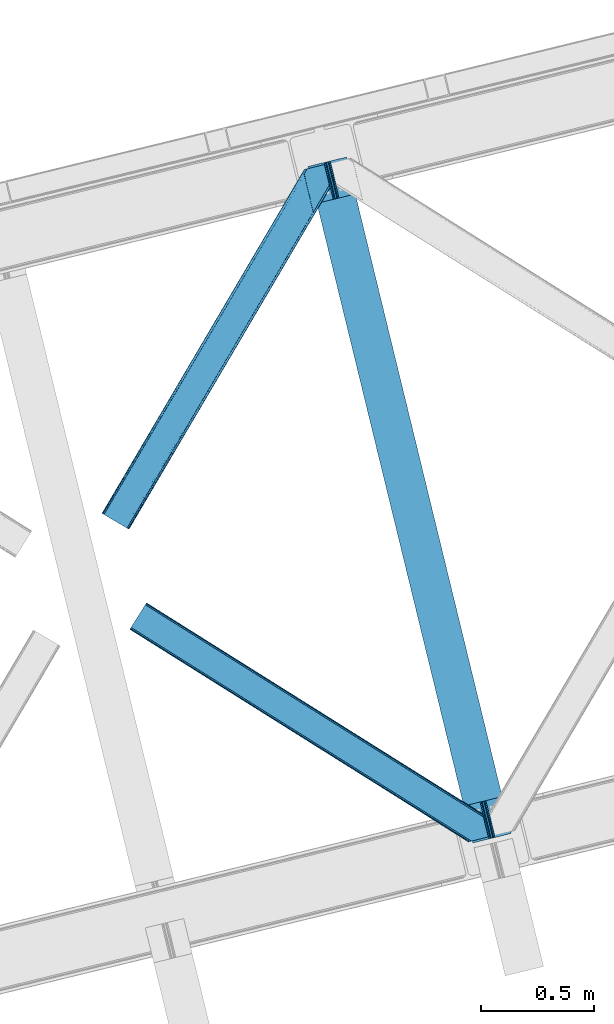
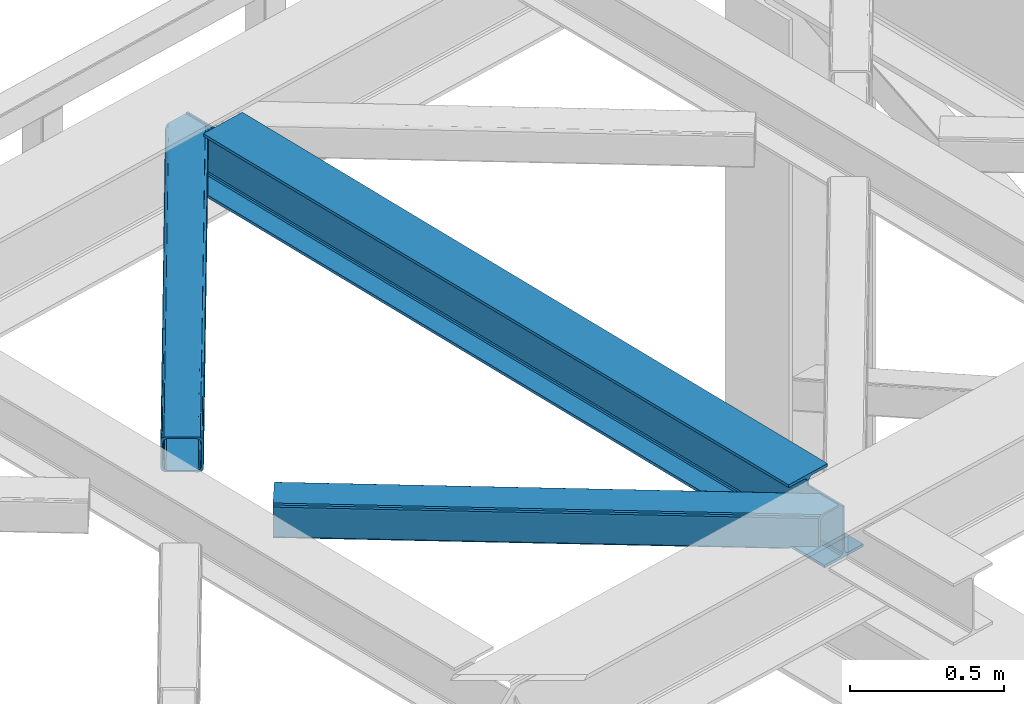
# One storey, part 25 of 93: 2 members, 1 beam.
"""IFC4 building model written with IfcOpenShell, lengths in millimetres."""

from ifc_helpers import new_model, entity, si_unit, converted_unit, derived_unit, direction, frame, origin, place, context, subcontext, project, spatial, triangles, polygons, material, type_object, element, save


model = new_model("IFC4")

# Units and contexts
model_context = context("Model", 3, precision=0.01, world=origin(), true_north=direction((6.12303176911189e-17, 1.0)))
plan_context = context("Plan", 3, precision=0.01, world=origin(), true_north=direction((6.12303176911189e-17, 1.0)))
body_context = subcontext(model_context, "Body", "Model", "MODEL_VIEW")
ifc_project = project(units=[si_unit("LENGTHUNIT", "METRE", prefix="MILLI"), si_unit("AREAUNIT", "SQUARE_METRE"), si_unit("VOLUMEUNIT", "CUBIC_METRE"), converted_unit("PLANEANGLEUNIT", "DEGREE", entity("IfcRatioMeasure", 0.0174532925199433), si_unit("PLANEANGLEUNIT", "RADIAN"), dimensions=[0, 0, 0, 0, 0, 0, 0]), si_unit("MASSUNIT", "GRAM", prefix="KILO"), derived_unit("MASSDENSITYUNIT", [(si_unit("MASSUNIT", "GRAM", prefix="KILO"), 1), (si_unit("LENGTHUNIT", "METRE"), -3)]), derived_unit("MOMENTOFINERTIAUNIT", [(si_unit("LENGTHUNIT", "METRE"), 4)]), si_unit("TIMEUNIT", "SECOND"), si_unit("FREQUENCYUNIT", "HERTZ"), si_unit("THERMODYNAMICTEMPERATUREUNIT", "DEGREE_CELSIUS"), derived_unit("THERMALTRANSMITTANCEUNIT", [(si_unit("MASSUNIT", "GRAM", prefix="KILO"), 1), (si_unit("THERMODYNAMICTEMPERATUREUNIT", "KELVIN"), -1), (si_unit("TIMEUNIT", "SECOND"), -3)]), derived_unit("VOLUMETRICFLOWRATEUNIT", [(si_unit("LENGTHUNIT", "METRE"), 3), (si_unit("TIMEUNIT", "SECOND"), -1)]), derived_unit("MASSFLOWRATEUNIT", [(si_unit("MASSUNIT", "GRAM", prefix="KILO"), 1), (si_unit("TIMEUNIT", "SECOND"), -1)]), derived_unit("ROTATIONALFREQUENCYUNIT", [(si_unit("TIMEUNIT", "SECOND"), -1)]), si_unit("ELECTRICCURRENTUNIT", "AMPERE"), si_unit("ELECTRICVOLTAGEUNIT", "VOLT"), si_unit("POWERUNIT", "WATT"), si_unit("FORCEUNIT", "NEWTON", prefix="KILO"), si_unit("ILLUMINANCEUNIT", "LUX"), si_unit("LUMINOUSFLUXUNIT", "LUMEN"), si_unit("LUMINOUSINTENSITYUNIT", "CANDELA"), derived_unit("USERDEFINED", [(si_unit("MASSUNIT", "GRAM", prefix="KILO"), -1), (si_unit("LENGTHUNIT", "METRE"), -2), (si_unit("TIMEUNIT", "SECOND"), 3), (si_unit("LUMINOUSFLUXUNIT", "LUMEN"), 1)]), derived_unit("LINEARVELOCITYUNIT", [(si_unit("LENGTHUNIT", "METRE"), 1), (si_unit("TIMEUNIT", "SECOND"), -1)]), si_unit("PRESSUREUNIT", "PASCAL"), derived_unit("USERDEFINED", [(si_unit("LENGTHUNIT", "METRE"), -2), (si_unit("MASSUNIT", "GRAM", prefix="KILO"), 1), (si_unit("TIMEUNIT", "SECOND"), -2)]), derived_unit("LINEARFORCEUNIT", [(si_unit("MASSUNIT", "GRAM", prefix="KILO"), 1), (si_unit("LENGTHUNIT", "METRE"), 1), (si_unit("TIMEUNIT", "SECOND"), -2), (si_unit("LENGTHUNIT", "METRE"), -1)]), derived_unit("PLANARFORCEUNIT", [(si_unit("MASSUNIT", "GRAM", prefix="KILO"), 1), (si_unit("LENGTHUNIT", "METRE"), 1), (si_unit("TIMEUNIT", "SECOND"), -2), (si_unit("LENGTHUNIT", "METRE"), -2)])], contexts=[model_context, plan_context])

# Site, building, storey
site_placement = place(None, origin())
site = spatial("IfcSite", under=ifc_project, at=site_placement, CompositionType="ELEMENT")
building_placement = place(site_placement, origin())
building = spatial("IfcBuilding", under=site, at=building_placement, CompositionType="ELEMENT")
storey_placement = place(building_placement, frame((0.0, 0.0, 15900.0)))
storey = spatial("IfcBuildingStorey", under=building, at=storey_placement, CompositionType="ELEMENT", Elevation=15900.0)

# Beam
ifc_material = material(Name="Metal painted (White)")
beam_type = type_object("IfcBeamType", PredefinedType="BEAM")
beam_placement = place(storey_placement, frame((-58178.5607525834, 3605.06510342686, 3441.0)))
element("IfcBeam", 1, at=beam_placement, inside=storey, type_object=beam_type, material=ifc_material, ObjectType="Steel Beam", PredefinedType="BEAM", context=body_context, shape_type="Tessellation", body=[
    polygons([(900.98534618944, 41.4445662733081, 11.000000000004), (900.98534618944, 41.4445662733081, 2.16573425859679e-12), (170.021610174761, 3040.13999372697, 2.16573425859679e-12), (170.021610174761, 3040.13999372697, 11.000000000004), (834.919806235814, 25.3403919499656, 11.000000000004), (103.956070221135, 3024.03581940362, 11.000000000004), (828.971056214522, 23.8903211957396, 12.2179274798217), (98.0073201998427, 3022.5857486494, 12.2179274798217), (823.927949458413, 22.6610105689194, 15.6862915010192), (92.964213443734, 3021.35643802258, 15.6862915010192), (820.558253255237, 21.8396114687113, 20.8770650821657), (89.5945172405581, 3020.53503892237, 20.8770650821657), (819.374973305543, 21.55117446212, 27.0000000000047), (88.4112372908723, 3020.24660191578, 27.0000000000047), (81.6103728838888, 3018.58881926485, 27.0000000000047), (81.6103728838801, 3018.58881926485, 203.000000000006), (88.4112372908723, 3020.24660191578, 203.000000000006), (0.0, 2998.69542745366, 2.16573425859679e-12), (0.0, 2998.69542745366, 10.9999999999997), (66.0655399536172, 3014.799601777, 11.000000000004), (72.0142899749184, 3016.24967253123, 12.2179274798217), (77.057396731027, 3017.47898315805, 15.6862915010192), (80.4270929342029, 3018.30038225826, 20.8770650821657), (819.374973305543, 21.5511744621206, 203.000000000006), (812.574108898559, 19.8933918111876, 203.000000000006), (812.574108898559, 19.8933918111881, 27.0000000000047), (811.390828948873, 19.6049548045968, 20.8770650821657), (808.021132745689, 18.7835557043887, 15.6862915010192), (802.978025989589, 17.5542450775691, 12.2179274798217), (797.029275968296, 16.1041743233425, 11.000000000004), (730.963736014679, 0.0, 10.9999999999997), (730.963736014679, -5.41433564649196e-13, 2.16573425859679e-12), (779.675212882749, 184.415062601691, 203.069791966819), (128.020401343495, 2857.75452019162, 203.000000000006), (128.24328213265, 2856.8401777572, 203.617301946336), (128.256196377177, 2856.7871977843, 217.000003693143), (779.530009633824, 185.010597404071, 217.000003676718), (779.530880241713, 185.007025963192, 204.00000679514), (772.96491171832, 182.385463974441, 203.006342981529), (772.742064056773, 183.299815969774, 203.617301946336), (772.729149812254, 183.352795942667, 217.000003693143), (121.455336555599, 2855.1293963229, 217.000003676718), (121.45446594771, 2855.13296776378, 204.00000679514), (121.310166358664, 2855.72494066435, 203.076120467494), (121.219536936511, 2856.09673754069, 203.000000000006), (780.71349435786, 185.298194377514, 223.122939328039), (784.082490766539, 186.122464201394, 228.313710402595), (789.125126170554, 187.353708426698, 231.782072735464), (795.073705041275, 188.80448128138, 232.999999602236), (861.139155906781, 204.909021065314, 232.999999283132), (861.137682570343, 204.915065042188, 243.999994005812), (691.116301666431, 163.469558245297, 243.999994827032), (691.117775002877, 163.463514268424, 233.000000104353), (757.183225868401, 179.568054052359, 232.999999785253), (763.132130996731, 181.017488520582, 231.782072861016), (768.17569550387, 182.244921343718, 228.313710479427), (771.546082413602, 183.063487001147, 223.12293937232), (120.271851831572, 2854.84179934945, 223.122939328039), (116.902855422893, 2854.01752952557, 228.313710402595), (111.860220018869, 2852.78628530027, 231.782072735464), (105.911641148174, 2851.33551244559, 232.999999602236), (39.8461902826505, 2835.23097266165, 232.999999283128), (39.8476636190881, 2835.22492868478, 243.999994005812), (209.869044522992, 2876.67043548167, 243.999994827032), (209.867571186554, 2876.67647945854, 233.000000104357), (143.802120321031, 2860.57193967461, 232.999999785253), (137.85321519271, 2859.12250520639, 231.782072861012), (132.809650685579, 2857.89507238325, 228.313710479427), (129.439263775838, 2857.07650672582, 223.12293937232)], [[[1, 2, 3, 4]], [[5, 1, 4, 6]], [[7, 5, 6, 8]], [[9, 7, 8, 10]], [[11, 9, 10, 12]], [[13, 11, 12, 14]], [[15, 16, 17, 14, 12, 10, 8, 6, 4, 3, 18, 19, 20, 21, 22, 23]], [[13, 24, 25, 26, 27, 28, 29, 30, 31, 32, 2, 1, 5, 7, 9, 11]], [[2, 32, 18, 3]], [[32, 31, 19, 18]], [[31, 30, 20, 19]], [[27, 26, 15, 23]], [[28, 27, 23, 22]], [[29, 28, 22, 21]], [[30, 29, 21, 20]], [[33, 24, 13, 14, 17, 34, 35, 36, 37, 38]], [[25, 39, 40, 41, 42, 43, 44, 16, 15, 26]], [[39, 25, 24, 33]], [[45, 34, 17, 16]], [[41, 40, 38, 37, 46, 47, 48, 49, 50, 51, 52, 53, 54, 55, 56, 57]], [[42, 58, 59, 60, 61, 62, 63, 64, 65, 66, 67, 68, 69, 36, 35, 43]], [[46, 37, 36, 69]], [[47, 46, 69, 68]], [[48, 47, 68, 67]], [[49, 48, 67, 66]], [[50, 49, 66, 65]], [[51, 50, 65, 64]], [[52, 51, 64, 63]], [[53, 52, 63, 62]], [[54, 53, 62, 61]], [[55, 54, 61, 60]], [[56, 55, 60, 59]], [[57, 56, 59, 58]], [[41, 57, 58, 42]]], closed=False),
])

# Members
member_type_1 = type_object("IfcMemberType", PredefinedType="BRACE")
member_1_placement = place(storey_placement, frame((-59092.2442382813, 4994.98929748535, 3511.0000579834)))
element("IfcMember", 2, at=member_1_placement, inside=storey, type_object=member_type_1, ObjectType="Steel Horizontal Brace", PredefinedType="BRACE", context=body_context, shape_type="Tessellation", body=[
    triangles([(105.565649414064, 8.87794647216742, 0.0), (15.0828002929702, 62.1479507446284, 0.0), (892.847827148435, 1346.1393447876, 0.0), (857.170935058595, 1492.50250396728, 0.0), (854.896655273435, 1501.83739929199, 1.33247680664135), (9.31105957031104, 65.5459991455073, 1.33247680664135), (852.966540527341, 1509.75145111084, 5.12526855468968), (4.4183349609375, 68.4260559082031, 5.12526855468968), (851.678247070311, 1515.03950042725, 10.8028289794929), (1.14876708984229, 70.3509384155268, 10.8028289794929), (851.222460937497, 1516.89636383057, 17.5000946044929), (0.0, 71.0264785766603, 17.5000946044929), (893.638476562497, 1342.89768218994, 0.155804443362285), (111.337390136716, 5.48047943115216, 1.33247680664135), (899.559045410155, 1344.34119873047, 1.33247680664135), (912.390820312503, 1347.46949615478, 10.8028289794929), (914.195361328122, 1347.90958557129, 17.5000946044929), (120.643798828125, 0.0, 17.5000946044929), (119.499682617185, 0.675540161132631, 10.8028289794929), (907.251599121097, 1346.21666564941, 5.12526855468968), (116.230114746089, 2.59984130859357, 5.12526855468968), (902.498400878903, 1345.05743408203, 17.9802978515654), (893.638476562497, 1342.89768218994, 9.69243164062573), (897.768457031249, 1343.90459747314, 12.1260040283232), (903.726232910158, 1345.35625305176, 19.4999725341804), (914.195361328122, 1347.90958557129, 19.4999725341804), (1011.61732177735, 1513.38611297607, 19.4999725341804), (1008.98957519532, 1524.16103668213, 19.4999725341804), (1011.61732177735, 1513.38611297607, 122.500662231447), (120.643798828125, 0.0, 122.500662231447), (114.61160888672, 3.55094604492206, 24.4996673583992), (1009.24072265625, 1523.14365692139, 24.4996673583992), (113.46749267578, 4.22706756591742, 17.8035644531265), (110.197924804685, 6.15136871337836, 12.1260040283232), (105.305200195311, 9.03200683593695, 8.3320495605476), (99.5334594726519, 12.4294738769531, 6.99957275390625), (892.685046386716, 1346.79976959229, 8.88434143066479), (890.471228027345, 1355.89688873291, 6.99957275390625), (21.114990234375, 58.5970046997072, 6.99957275390625), (859.547534179685, 1482.74496002197, 6.99957275390625), (853.961828613283, 1505.65984039307, 18.5000335693367), (851.222460937497, 1516.89636383057, 18.5000335693367), (854.096704101561, 1505.10871124268, 17.8803039550803), (855.343139648438, 1499.99390716553, 12.1260040283232), (857.273254394531, 1492.07985534668, 8.3320495605476), (1009.24072265625, 1523.14365692139, 115.501089477541), (114.61160888672, 3.55094604492206, 115.501089477541), (1008.78493652344, 1525.00052032471, 122.196029663086), (113.46749267578, 4.22706756591742, 122.196029663086), (1007.49664306641, 1530.28856964111, 127.87475280762), (110.197924804685, 6.15136871337836, 127.87475280762), (1005.57117919922, 1538.20262145996, 131.667544555665), (105.305200195311, 9.03200683593695, 131.667544555665), (1003.29224853516, 1547.53751678467, 133.000021362306), (99.5334594726519, 12.4294738769531, 133.000021362306), (851.952648925784, 1518.13291625977, 19.4999725341804), (854.580395507815, 1507.35799255371, 19.4999725341804), (851.780566406247, 1517.83991088867, 19.2639404296897), (854.43156738281, 1506.94987792969, 19.2592895507842), (851.589880371095, 1517.51434936523, 19.0000030517585), (854.268786621091, 1506.50920715332, 19.0000030517585), (851.394543457034, 1517.1887878418, 18.736065673831), (854.110656738281, 1506.06795501709, 18.7407165527366), (908.014343261719, 1598.12628936768, 19.4999725341804), (897.545214843747, 1595.57353820801, 19.4999725341804), (1011.16618652343, 1515.24297637939, 129.197927856447), (1009.8778930664, 1520.53160705566, 134.874325561526), (1008.43146972657, 1526.45624542236, 137.999716186525), (986.311889648438, 1617.21117095947, 137.999716186525), (986.311889648438, 1617.21117095947, 133.000021362306), (897.545214843747, 1595.57353820801, 122.500662231447), (0.0, 71.0264785766603, 122.500662231447), (7.18095703124709, 66.799411010742, 17.8035644531265), (10.4505249023423, 64.8751098632811, 12.1260040283232), (6.03218994140479, 67.4755325317383, 24.4996673583992), (907.028356933595, 1597.88560638428, 24.4996673583992), (15.3432495117158, 61.9944717407225, 8.3320495605476), (908.832897949222, 1598.32511444092, 122.196029663086), (899.349755859374, 1596.01362762451, 129.197927856447), (904.48897705078, 1597.26645812988, 134.874325561526), (930.738537597659, 1603.66490478516, 133.000021362306), (910.246765136719, 1598.66986083984, 137.999716186525), (921.664672851563, 1601.45341186523, 131.667544555665), (913.972119140628, 1599.57794494629, 127.87475280762), (907.028356933595, 1597.88560638428, 115.501089477541), (21.114990234375, 58.5970046997072, 133.000021362306), (6.03218994140479, 67.4755325317383, 115.501089477541), (15.3432495117158, 61.9944717407225, 131.667544555665), (10.4505249023423, 64.8751098632811, 127.87475280762), (7.18095703124709, 66.799411010742, 122.196029663086), (119.499682617185, 0.675540161132631, 129.197927856447), (116.230114746089, 2.59984130859357, 134.874325561526), (111.337390136716, 5.48047943115216, 138.667117309571), (105.565649414064, 8.87794647216742, 139.999594116212), (15.0828002929702, 62.1479507446284, 139.999594116212), (9.31105957031104, 65.5459991455073, 138.667117309571), (4.4183349609375, 68.4260559082031, 134.874325561526), (1.14876708984229, 70.3509384155268, 129.197927856447), (896.991760253906, 1576.15553741455, 137.999716186525), (938.18924560547, 1407.14434204102, 137.999716186525), (899.024194335936, 1563.5946762085, 139.999594116212), (897.042919921878, 1571.72266845703, 138.999655151369), (896.801074218747, 1573.13653564453, 138.639212036134), (896.926647949222, 1575.15443572998, 138.211331176761), (896.86153564453, 1574.14112548828, 138.427597045898), (937.477661132813, 1407.08562469482, 138.29272155762), (937.077685546872, 1408.09486541748, 138.646188354494), (936.682360839841, 1409.10410614014, 138.999655151369), (934.701086425783, 1417.23209838867, 139.999594116212)], [[1, 2, 3], [4, 3, 2], [5, 4, 6], [2, 6, 4], [7, 5, 8], [6, 8, 5], [9, 7, 10], [8, 10, 7], [11, 9, 12], [10, 12, 9], [1, 3, 13], [13, 14, 1], [13, 15, 14], [16, 17, 18], [18, 19, 16], [20, 16, 19], [19, 21, 20], [15, 20, 21], [21, 14, 15], [20, 22, 16], [23, 24, 15], [23, 15, 13], [15, 24, 20], [16, 25, 17], [20, 24, 22], [16, 22, 25], [26, 17, 25], [26, 25, 27], [28, 27, 25], [27, 29, 26], [30, 26, 29], [26, 18, 17], [30, 18, 26], [31, 32, 25], [25, 33, 31], [25, 22, 33], [32, 28, 25], [33, 22, 24], [34, 24, 23], [23, 35, 34], [36, 35, 37], [37, 38, 36], [23, 37, 35], [24, 34, 33], [39, 36, 38], [38, 40, 39], [9, 11, 41], [11, 42, 41], [43, 9, 41], [43, 7, 9], [44, 7, 43], [5, 44, 45], [44, 5, 7], [4, 5, 45], [45, 40, 4], [37, 23, 13], [37, 3, 38], [3, 40, 38], [40, 3, 4], [37, 13, 3], [46, 32, 31], [31, 47, 46], [48, 46, 49], [47, 49, 46], [50, 48, 51], [49, 51, 48], [52, 50, 53], [51, 53, 50], [54, 52, 55], [53, 55, 52], [56, 57, 58], [59, 58, 57], [58, 59, 60], [61, 60, 59], [60, 61, 62], [63, 62, 61], [62, 63, 42], [41, 42, 63], [57, 56, 64], [65, 64, 56], [66, 48, 67], [46, 29, 27], [27, 32, 46], [32, 27, 28], [48, 29, 46], [66, 29, 48], [50, 68, 67], [52, 68, 50], [67, 48, 50], [52, 54, 68], [54, 69, 68], [70, 69, 54], [71, 60, 62], [58, 60, 71], [71, 56, 58], [56, 71, 65], [42, 12, 72], [12, 42, 11], [71, 42, 72], [42, 71, 62], [73, 74, 44], [75, 73, 43], [43, 41, 75], [43, 57, 75], [64, 76, 57], [75, 57, 76], [44, 43, 73], [45, 44, 74], [74, 77, 45], [40, 45, 77], [77, 39, 40], [78, 79, 80], [81, 82, 69], [69, 70, 81], [81, 83, 82], [84, 82, 83], [80, 82, 84], [78, 71, 79], [85, 71, 78], [80, 84, 78], [65, 76, 64], [85, 65, 71], [76, 65, 85], [86, 54, 55], [54, 86, 81], [70, 54, 81], [76, 85, 75], [87, 75, 85], [83, 81, 86], [86, 88, 83], [84, 83, 88], [88, 89, 84], [78, 84, 89], [89, 90, 78], [85, 78, 90], [90, 87, 85], [91, 51, 49], [47, 18, 30], [91, 49, 30], [91, 92, 51], [49, 47, 30], [51, 92, 93], [55, 94, 95], [94, 53, 93], [53, 94, 55], [53, 51, 93], [19, 34, 21], [31, 18, 47], [18, 33, 19], [33, 18, 31], [19, 33, 34], [1, 36, 2], [14, 21, 34], [34, 35, 14], [35, 36, 1], [1, 14, 35], [89, 96, 97], [95, 86, 55], [95, 88, 86], [88, 95, 96], [89, 88, 96], [87, 72, 12], [98, 90, 89], [97, 98, 89], [90, 98, 72], [87, 90, 72], [6, 74, 8], [2, 36, 39], [39, 77, 2], [77, 74, 6], [6, 2, 77], [10, 8, 74], [12, 75, 87], [73, 12, 10], [12, 73, 75], [73, 10, 74], [99, 68, 82], [99, 100, 68], [68, 69, 82], [96, 95, 101], [101, 102, 96], [97, 96, 103], [104, 97, 105], [104, 99, 97], [97, 103, 105], [82, 80, 99], [97, 99, 80], [102, 103, 96], [79, 71, 98], [72, 98, 71], [80, 79, 97], [98, 97, 79], [92, 67, 100], [100, 93, 92], [67, 68, 100], [106, 107, 93], [94, 93, 107], [107, 108, 94], [108, 109, 94], [66, 67, 92], [92, 91, 66], [29, 66, 91], [91, 30, 29], [95, 94, 109], [109, 101, 95], [107, 103, 102], [105, 103, 107], [106, 104, 105], [100, 99, 104], [107, 106, 105], [102, 108, 107], [102, 101, 109], [109, 108, 102]]),
])
member_type_2 = type_object("IfcMemberType", PredefinedType="BRACE")
member_2_placement = place(storey_placement, frame((-58968.5122558594, 3609.34131774902, 3511.0000579834)))
element("IfcMember", 3, at=member_2_placement, inside=storey, type_object=member_type_2, ObjectType="Steel Horizontal Brace", PredefinedType="BRACE", context=body_context, shape_type="Tessellation", body=[
    triangles([(9.3017578125, 956.602365875244, 0.0), (65.121606445311, 1045.53560028076, 0.0), (1381.50172119141, 219.293009948731, 0.0), (1417.17861328126, 72.9304321289064, 0.0), (1422.67130126953, 50.3934356689456, 10.8028289794929), (1423.12708740235, 48.5365722656252, 17.5000946044929), (0.0, 941.780014801026, 17.5000946044929), (0.706933593748545, 942.908434295654, 10.8028289794929), (1421.3830078125, 55.6811943054204, 5.12526855468968), (2.72076416015625, 946.121319580079, 5.12526855468968), (1419.45289306641, 63.5952461242678, 1.33247680664135), (5.73918457031687, 950.930037689209, 1.33247680664135), (68.6795288085923, 1051.20763778687, 1.33247680664135), (71.6979492187529, 1056.016355896, 5.12526855468968), (1377.30662841797, 236.497192382813, 5.17061462402489), (73.7164306640625, 1059.22924118042, 10.8028289794929), (1382.10168457031, 238.005530548096, 10.8028289794929), (1383.90622558594, 238.4456199646, 17.5000946044929), (74.423364257811, 1060.35766067505, 17.5000946044929), (1379.22744140626, 228.628195953369, 1.33247680664135), (1377.23221435547, 236.818103027344, 17.5198608398459), (1383.90622558594, 238.4456199646, 18.5197998046897), (1378.19959716797, 237.055007171631, 18.5197998046897), (1379.50649414063, 231.698357391358, 18.5197998046897), (1563.91384277344, 125.462400054932, 18.5197998046897), (1566.64855957031, 114.236631774902, 18.5197998046897), (1563.91384277344, 125.462400054932, 122.500662231447), (74.423364257811, 1060.35766067505, 122.500662231447), (1564.36497802735, 123.605536651612, 129.197927856447), (73.7164306640625, 1059.22924118042, 129.197927856447), (1565.65327148438, 118.317487335205, 134.874325561526), (71.6979492187529, 1056.016355896, 134.874325561526), (1567.58338623047, 110.403726196289, 138.667117309571), (68.6795288085923, 1051.20763778687, 138.667117309571), (1569.85766601563, 101.068540191651, 139.999594116212), (65.121606445311, 1045.53560028076, 139.999594116212), (67.9772460937529, 1050.08735733032, 12.1260040283232), (1379.67392578125, 226.784703826905, 12.1260040283232), (1378.42749023438, 231.905030822754, 17.5198608398459), (69.9957275390625, 1053.30053329468, 17.8035644531265), (1566.29044189453, 115.704856109619, 24.4996673583992), (70.702661132811, 1054.42895278931, 24.4996673583992), (1381.60404052735, 218.870652008057, 8.3320495605476), (64.9588256835923, 1045.27892990112, 8.3320495605476), (1383.87832031251, 209.535466003418, 6.99957275390625), (61.400903320311, 1039.60660171509, 6.99957275390625), (13.0224609375, 962.531073760987, 6.99957275390625), (1414.80201416016, 82.6876853942872, 6.99957275390625), (1419.00640869141, 65.4387382507325, 12.1260040283232), (1420.25284423828, 60.3181205749515, 17.5198608398459), (1417.07629394531, 73.3527900695804, 8.3320495605476), (1566.29044189453, 115.704856109619, 115.501089477541), (70.702661132811, 1054.42895278931, 115.501089477541), (1569.95998535157, 100.646182250977, 131.667544555665), (1572.23891601563, 91.3109962463382, 133.000021362306), (61.400903320311, 1039.60660171509, 133.000021362306), (64.9588256835923, 1045.27892990112, 131.667544555665), (1568.03452148438, 108.559943389893, 127.87475280762), (67.9772460937529, 1050.08735733032, 127.87475280762), (1566.74622802735, 113.847992706299, 122.196029663086), (69.9957275390625, 1053.30053329468, 122.196029663086), (1589.21927490235, 21.6376327514649, 133.000021362306), (1589.21927490235, 21.6376327514649, 139.999594116212), (9.3017578125, 956.602365875244, 139.999594116212), (1524.16743164063, 5.77958908081064, 139.999594116212), (1515.09356689453, 3.5678054809573, 138.667117309571), (5.73918457031687, 950.930037689209, 138.667117309571), (1507.4010131836, 1.69262924194345, 134.874325561526), (2.72076416015625, 946.121319580079, 134.874325561526), (1502.26179199219, 0.439798736572357, 129.197927856447), (0.706933593748545, 942.908434295654, 129.197927856447), (1500.45725097656, 0.0, 122.500662231447), (0.0, 941.780014801026, 122.500662231447), (1424.34096679688, 47.7738281250004, 18.5197998046897), (1500.45725097656, 0.0, 18.5197998046897), (1421.60625, 58.9995964050295, 18.5197998046897), (1511.36821289063, 2.65972137451172, 18.5197998046897), (3.720703125, 947.708722686767, 24.4996673583992), (1509.94039306641, 2.31177749633798, 24.4996673583992), (4.42763671874854, 948.837142181397, 17.8035644531265), (1420.92722167969, 59.6588584899905, 18.0198303222678), (6.44611816406541, 952.050318145752, 12.1260040283232), (9.45988769531687, 956.858745574952, 8.3320495605476), (6.44611816406541, 952.050318145752, 127.87475280762), (13.0224609375, 962.531073760987, 133.000021362306), (9.45988769531687, 956.858745574952, 131.667544555665), (3.720703125, 947.708722686767, 115.501089477541), (4.42763671874854, 948.837142181397, 122.196029663086), (1524.57670898438, 5.87958297729529, 131.667544555665), (1516.88415527344, 4.00440673828143, 127.87475280762), (1511.74493408203, 2.75157623291034, 122.196029663086), (1533.65057373047, 8.09136657714862, 133.000021362306), (1509.94039306641, 2.31177749633798, 115.501089477541)], [[1, 2, 3], [3, 4, 1], [5, 6, 7], [7, 8, 5], [9, 5, 8], [8, 10, 9], [11, 9, 10], [10, 12, 11], [4, 11, 12], [12, 1, 4], [13, 14, 15], [16, 17, 15], [15, 14, 16], [18, 17, 19], [16, 19, 17], [20, 3, 2], [2, 13, 20], [15, 20, 13], [18, 21, 17], [18, 22, 23], [17, 21, 15], [21, 18, 23], [24, 22, 25], [22, 24, 23], [25, 26, 24], [25, 22, 27], [19, 22, 18], [22, 28, 27], [19, 28, 22], [29, 27, 30], [28, 30, 27], [31, 29, 32], [30, 32, 29], [33, 31, 34], [32, 34, 31], [35, 33, 36], [34, 36, 33], [37, 38, 39], [39, 40, 37], [24, 41, 42], [24, 26, 41], [42, 40, 39], [43, 38, 44], [37, 44, 38], [45, 43, 46], [44, 46, 43], [46, 47, 45], [48, 45, 47], [3, 48, 4], [43, 20, 38], [39, 15, 21], [15, 39, 38], [38, 20, 15], [43, 3, 20], [3, 45, 48], [43, 45, 3], [9, 49, 50], [50, 5, 9], [6, 5, 50], [49, 11, 51], [51, 4, 48], [4, 51, 11], [49, 9, 11], [41, 52, 53], [53, 42, 41], [54, 55, 56], [56, 57, 54], [58, 54, 57], [57, 59, 58], [60, 58, 59], [59, 61, 60], [52, 60, 61], [61, 53, 52], [58, 31, 33], [58, 33, 54], [55, 54, 35], [60, 31, 58], [62, 55, 63], [35, 63, 55], [54, 33, 35], [29, 31, 60], [25, 27, 52], [41, 25, 52], [25, 41, 26], [29, 60, 27], [60, 52, 27], [64, 35, 36], [35, 64, 65], [63, 35, 65], [66, 65, 64], [64, 67, 66], [68, 66, 67], [67, 69, 68], [70, 68, 69], [69, 71, 70], [72, 70, 71], [71, 73, 72], [74, 72, 6], [74, 75, 72], [73, 6, 72], [73, 7, 6], [74, 76, 77], [77, 75, 74], [78, 79, 76], [76, 80, 78], [76, 81, 80], [79, 77, 76], [50, 82, 80], [50, 49, 82], [51, 48, 83], [47, 83, 48], [49, 51, 82], [83, 82, 51], [16, 37, 40], [42, 28, 19], [16, 40, 19], [16, 14, 37], [40, 42, 19], [37, 14, 13], [46, 2, 1], [2, 44, 13], [44, 2, 46], [44, 37, 13], [30, 59, 32], [53, 28, 42], [28, 61, 30], [61, 28, 53], [30, 61, 59], [36, 56, 64], [34, 32, 59], [59, 57, 34], [57, 56, 36], [36, 34, 57], [82, 12, 10], [1, 47, 46], [1, 83, 47], [83, 1, 12], [82, 83, 12], [78, 7, 73], [8, 80, 82], [10, 8, 82], [80, 8, 7], [78, 80, 7], [67, 84, 69], [64, 56, 85], [85, 86, 64], [86, 84, 67], [67, 64, 86], [71, 69, 84], [73, 87, 78], [88, 73, 71], [73, 88, 87], [88, 71, 84], [89, 65, 66], [90, 66, 68], [91, 68, 70], [92, 63, 65], [89, 66, 90], [62, 63, 92], [89, 92, 65], [91, 90, 68], [72, 93, 91], [93, 72, 75], [79, 75, 77], [75, 79, 93], [72, 91, 70], [85, 55, 92], [85, 56, 55], [55, 62, 92], [91, 93, 88], [87, 88, 93], [90, 91, 84], [88, 84, 91], [89, 90, 86], [84, 86, 90], [92, 89, 85], [86, 85, 89], [93, 79, 78], [78, 87, 93]]),
])

save(model, "model.ifc")
